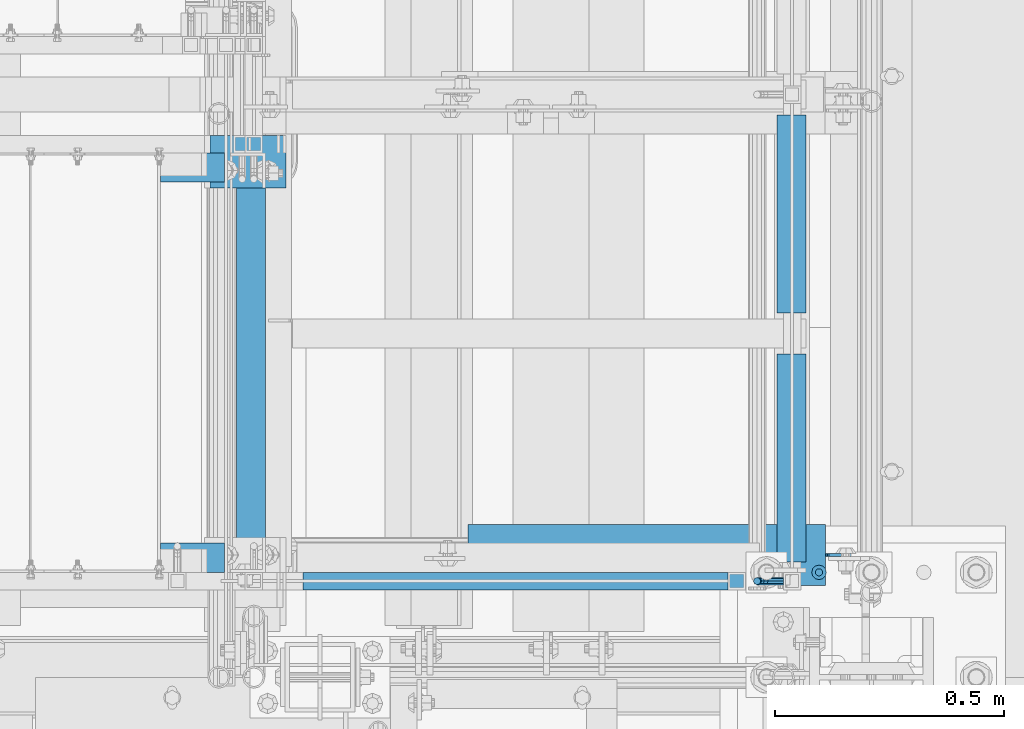
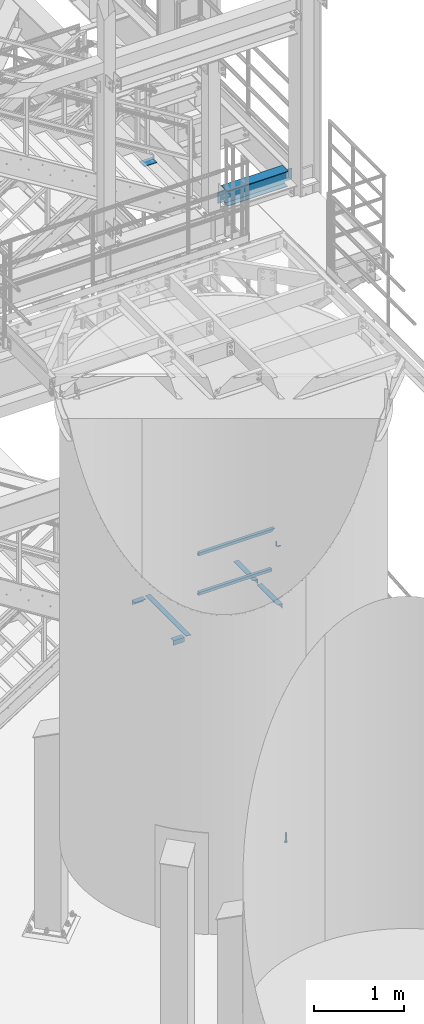
# One storey, part 1156 of 1876: 11 beams, 7 elements without a shape of their own.
"""IFC2X3 building model written with IfcOpenShell, lengths in millimetres."""

import ifcopenshell
import ifcopenshell.guid

model = None  # the IFC model being written
_history = None  # IfcOwnerHistory: only IFC2X3 demands one
_inside = {}  # id of a spatial element -> (the spatial element, [elements in it])
_under = {}  # id of a project, library or spatial element -> (it, [spatial elements below it])
_declared = {}  # id of a project -> (the project, [libraries it declares])
_typed = {}  # id of a type object -> (the type object, [elements of that type])
_made_of = {}  # id of a material, layer set ... -> (it, [elements and type objects made of it])


def new_model(schema):
    """Start an empty IFC model of exactly this schema.

    Asked for "IFC4X3", IfcOpenShell would pick the latest addendum, in which some entities
    have other attributes; the version numbers below select the first issue.
    IFC2X3 requires an IfcOwnerHistory on every rooted entity: one is made here for all.
    """
    global model, _history
    if schema == "IFC4X3":
        model = ifcopenshell.file(schema_version=(4, 3, 0, 0))
    else:
        model = ifcopenshell.file(schema=schema)
    _inside.clear()
    _under.clear()
    _declared.clear()
    _typed.clear()
    _made_of.clear()
    _history = None
    if model.schema == "IFC2X3":
        org = make("IfcOrganization", Name="unknown")
        user = make(
            "IfcPersonAndOrganization",
            ThePerson=make("IfcPerson", FamilyName="unknown"),
            TheOrganization=org,
        )
        app = make(
            "IfcApplication",
            ApplicationDeveloper=org,
            Version="unknown",
            ApplicationFullName="unknown",
            ApplicationIdentifier="unknown",
        )
        _history = make(
            "IfcOwnerHistory",
            OwningUser=user,
            OwningApplication=app,
            ChangeAction="ADDED",
            CreationDate=0,
        )
    return model


def make(cls, **values):
    """One entity of the class cls with the attributes given. An attribute that is None is left unset."""
    return model.create_entity(
        cls, **{name: value for name, value in values.items() if value is not None}
    )


def rooted(cls, **values):
    """An entity with a GlobalId (a new one), such as an element, a storey or a relation."""
    return make(cls, GlobalId=ifcopenshell.guid.new(), OwnerHistory=_history, **values)


def si_unit(unit_type, name, prefix=None):
    """IfcSIUnit, for example si_unit("LENGTHUNIT", "METRE", prefix="MILLI")."""
    return make("IfcSIUnit", UnitType=unit_type, Prefix=prefix, Name=name)


def assignment(units):
    """IfcUnitAssignment: the units of a project."""
    return None if units is None else make("IfcUnitAssignment", Units=units)


def point(xyz):
    """IfcCartesianPoint."""
    return None if xyz is None else make("IfcCartesianPoint", Coordinates=xyz)


def direction(xyz):
    """IfcDirection."""
    return None if xyz is None else make("IfcDirection", DirectionRatios=xyz)


def frame(location, z_axis=None, x_axis=None):
    """IfcAxis2Placement3D, a coordinate frame: its origin and axes. An axis left out is left unset."""
    return make(
        "IfcAxis2Placement3D",
        Location=point(location),
        Axis=direction(z_axis),
        RefDirection=direction(x_axis),
    )


def origin_with_axes():
    """The frame at (0, 0, 0) with the z axis (0, 0, 1) and the x axis (1, 0, 0) written out."""
    return frame((0.0, 0.0, 0.0), z_axis=(0.0, 0.0, 1.0), x_axis=(1.0, 0.0, 0.0))


def place(relative_to, where):
    """IfcLocalPlacement: puts the frame where relative to a parent placement (None: the world)."""
    return make(
        "IfcLocalPlacement", PlacementRelTo=relative_to, RelativePlacement=where
    )


def context(
    kind, dimensions, precision=None, world=None, true_north=None, identifier=None
):
    """IfcGeometricRepresentationContext, for example the 3D "Model" context."""
    return make(
        "IfcGeometricRepresentationContext",
        ContextIdentifier=identifier,
        ContextType=kind,
        CoordinateSpaceDimension=dimensions,
        Precision=precision,
        WorldCoordinateSystem=world,
        TrueNorth=true_north,
    )


def subcontext(parent, identifier, kind, view, scale=None):
    """IfcGeometricRepresentationSubContext, for example "Body" below "Model"."""
    return make(
        "IfcGeometricRepresentationSubContext",
        ContextIdentifier=identifier,
        ContextType=kind,
        ParentContext=parent,
        TargetScale=scale,
        TargetView=view,
    )


def project(units=None, contexts=None):
    """IfcProject with its units and contexts."""
    return rooted(
        "IfcProject",
        Name="project",
        RepresentationContexts=contexts,
        UnitsInContext=assignment(units),
    )


def spatial(cls, under=None, at=None, **own):
    """A site, building, storey or space (cls), placed at a placement, below another one or the project."""
    s = rooted(cls, ObjectPlacement=at, **own)
    if under is not None:
        _under.setdefault(under.id(), (under, []))[1].append(s)
    return s


def faces_of(points, faces, orient=None, outer=None):
    """IfcFace entities. A face is a list of loops; a loop is a list of indices into points, from 0.

    orient and outer hold one flag for each loop. By default every Orientation is true, the
    first loop of a face is its IfcFaceOuterBound and the others are IfcFaceBound.
    """
    made = []
    for i, loops in enumerate(faces):
        bounds = []
        for j, loop in enumerate(loops):
            is_outer = j == 0 if outer is None else outer[i][j]
            bounds.append(
                make(
                    "IfcFaceOuterBound" if is_outer else "IfcFaceBound",
                    Bound=make("IfcPolyLoop", Polygon=[points[k] for k in loop]),
                    Orientation=True if orient is None else orient[i][j],
                )
            )
        made.append(make("IfcFace", Bounds=bounds))
    return made


def faceted_brep(points, faces, orient=None, outer=None, voids=None):
    """IfcFacetedBrep: a solid bounded by flat faces; with voids (closed shells), ...WithVoids."""
    shared = [point(p) for p in points]
    hull = make("IfcClosedShell", CfsFaces=faces_of(shared, faces, orient, outer))
    if voids is None:
        return make("IfcFacetedBrep", Outer=hull)
    return make(
        "IfcFacetedBrepWithVoids",
        Outer=hull,
        Voids=[
            make(cls, CfsFaces=faces_of(shared, fs, o, b)) for cls, fs, o, b in voids
        ],
    )


def shape(context_of_items, identifier, shape_type, items):
    """IfcShapeRepresentation: the items that make up one representation, for example the "Body"."""
    return make(
        "IfcShapeRepresentation",
        ContextOfItems=context_of_items,
        RepresentationIdentifier=identifier,
        RepresentationType=shape_type,
        Items=items,
    )


def material(Name=None, Category=None):
    """IfcMaterial."""
    return make("IfcMaterial", Name=Name, Category=Category)


def made_of(thing, what):
    """Note that an element or type object is made of a material, layer set ...; save() writes the relation."""
    if what is not None:
        _made_of.setdefault(what.id(), (what, []))[1].append(thing)
    return thing


def type_object(cls, material=None, **own):
    """A type object (cls), such as IfcWallType, which elements share."""
    return made_of(rooted(cls, **own), material)


def element(
    cls,
    number,
    at=None,
    inside=None,
    cuts=None,
    type_object=None,
    material=None,
    context=None,
    identifier="Body",
    shape_type=None,
    held_by="IfcProductDefinitionShape",
    body=None,
    shapes=None,
    **own,
):
    """One element of the class cls, such as IfcWall. Its Tag is "e" and its number.

    at: its placement. inside: the storey or other place that contains it. cuts: it is an
    opening in that element (IfcRelVoidsElement). A single representation is given by context,
    identifier, shape_type and body (its items); several are given by shapes. held_by: the class
    of the entity that holds the representations. save() writes the other relations.
    """
    e = rooted(cls, Tag="e%d" % number, ObjectPlacement=at, **own)
    if body is not None:
        shapes = [shape(context, identifier, shape_type, body)]
    if shapes is not None:
        e.Representation = make(held_by, Representations=shapes)
    if inside is not None:
        _inside.setdefault(inside.id(), (inside, []))[1].append(e)
    if cuts is not None:
        rooted(
            "IfcRelVoidsElement", RelatingBuildingElement=cuts, RelatedOpeningElement=e
        )
    if type_object is not None:
        _typed.setdefault(type_object.id(), (type_object, []))[1].append(e)
    return made_of(e, material)


def aggregate(whole, parts):
    """IfcRelAggregates: a whole, such as a stair, and the parts it consists of."""
    return rooted("IfcRelAggregates", RelatingObject=whole, RelatedObjects=parts)


def save(model, path):
    """Write the relations noted so far, then the file.

    IfcRelAggregates (storeys below a building ...), IfcRelContainedInSpatialStructure (elements
    in a storey), IfcRelDefinesByType, IfcRelAssociatesMaterial and IfcRelDeclares: one each for
    every whole, place, type object, material and project.
    """
    for whole, parts in _under.values():
        aggregate(whole, parts)
    for where, things in _inside.values():
        rooted(
            "IfcRelContainedInSpatialStructure",
            RelatedElements=things,
            RelatingStructure=where,
        )
    for kind, things in _typed.values():
        rooted("IfcRelDefinesByType", RelatedObjects=things, RelatingType=kind)
    for what, things in _made_of.values():
        rooted("IfcRelAssociatesMaterial", RelatedObjects=things, RelatingMaterial=what)
    for by, libraries in _declared.values():
        rooted("IfcRelDeclares", RelatingContext=by, RelatedDefinitions=libraries)
    model.write(path)


model = new_model("IFC2X3")

# Units and contexts
model_context = context("Model", 3, precision=1e-05, world=origin_with_axes())
body_context = subcontext(model_context, "Body", "Model", "MODEL_VIEW")
ifc_project = project(units=[si_unit("LENGTHUNIT", "METRE", prefix="MILLI"), si_unit("AREAUNIT", "SQUARE_METRE"), si_unit("VOLUMEUNIT", "CUBIC_METRE"), si_unit("MASSUNIT", "GRAM", prefix="KILO"), si_unit("TIMEUNIT", "SECOND"), si_unit("PLANEANGLEUNIT", "RADIAN"), si_unit("SOLIDANGLEUNIT", "STERADIAN"), si_unit("THERMODYNAMICTEMPERATUREUNIT", "DEGREE_CELSIUS"), si_unit("LUMINOUSINTENSITYUNIT", "LUMEN")], contexts=[model_context])

# Site, building, storey
site_placement = place(None, origin_with_axes())
site = spatial("IfcSite", under=ifc_project, at=site_placement, CompositionType="ELEMENT")
building_placement = place(site_placement, origin_with_axes())
building = spatial("IfcBuilding", under=site, at=building_placement, Name="Undefined", CompositionType="ELEMENT")
storey_placement = place(building_placement, origin_with_axes())
storey = spatial("IfcBuildingStorey", under=building, at=storey_placement, Name="Undefined", CompositionType="ELEMENT", Elevation=0.0)

# Assembly, beams
assembly_1_placement = place(storey_placement, origin_with_axes())
assembly_1 = element("IfcElementAssembly", 1, at=assembly_1_placement, inside=storey, Name="STRINGER", AssemblyPlace="NOTDEFINED", PredefinedType="RIGID_FRAME")
ifc_material_1 = material(Name="STEEL/A36")
beam_type_1 = type_object("IfcBeamType", Name="L2-1/2X2-1/2X1/4", PredefinedType="NOTDEFINED")
beam_1_placement = place(assembly_1_placement, frame((7445.37500036358, -6861.17450143954, 2266.27941824708), z_axis=(0.0, 0.0, -1.0), x_axis=(0.0, 1.0, 0.0)))
beam_1 = element("IfcBeam", 2, at=beam_1_placement, type_object=beam_type_1, material=ifc_material_1, Name="ANGLE", ObjectType="L2-1/2X2-1/2X1/4", context=body_context, shape_type="Brep", body=[
    faceted_brep([(0.0, 31.75, -31.75), (0.0, 31.75, 31.75), (454.024500380441, 31.7499999997981, 31.75), (454.024500380441, 31.7499999997981, -31.75), (0.0, 25.3999999999996, 31.75), (454.024500380438, 25.3999999997977, 31.75), (0.0, 25.3999999999996, -25.3999999999996), (454.024500380438, 25.3999999997977, -25.4000000000001), (0.0, -31.75, -25.3999999999996), (454.024500380413, -31.7500000002019, -25.4000000000001), (0.0, -31.75, -31.75), (454.024500380413, -31.7500000002019, -31.75)], [[[0, 1, 2, 3]], [[1, 4, 5, 2]], [[4, 6, 7, 5]], [[6, 8, 9, 7]], [[8, 10, 11, 9]], [[10, 0, 3, 11]], [[5, 7, 9, 11, 3, 2]], [[10, 8, 6, 4, 1, 0]]]),
])
beam_2_placement = place(assembly_1_placement, frame((7445.3749994372, -6318.25000170957, 2266.27941824787), z_axis=(0.0, 0.0, -1.0), x_axis=(0.0, 1.0, 0.0)))
beam_2 = element("IfcBeam", 3, at=beam_2_placement, type_object=beam_type_1, material=ifc_material_1, Name="ANGLE", ObjectType="L2-1/2X2-1/2X1/4", context=body_context, shape_type="Brep", body=[
    faceted_brep([(0.0, 31.75, -31.75), (0.0, 31.75, 31.75), (431.800000762049, 31.75, 31.75), (431.800000762049, 31.75, -31.75), (0.0, 25.3999999999996, 31.75), (431.800000762049, 25.3999999999996, 31.75), (0.0, 25.3999999999996, -25.3999999999996), (431.800000762049, 25.3999999999996, -25.4000000000001), (0.0, -31.75, -25.3999999999996), (431.800000762049, -31.75, -25.4000000000001), (0.0, -31.75, -31.75), (431.800000762049, -31.75, -31.75)], [[[0, 1, 2, 3]], [[1, 4, 5, 2]], [[4, 6, 7, 5]], [[6, 8, 9, 7]], [[8, 10, 11, 9]], [[10, 0, 3, 11]], [[5, 7, 9, 11, 3, 2]], [[10, 8, 6, 4, 1, 0]]]),
])
beam_3_placement = place(assembly_1_placement, frame((6267.44999998606, -6870.69999887623, 2266.27941810345), z_axis=(0.0, 0.0, -1.0), x_axis=(0.0, 1.0, 0.0)))
beam_3 = element("IfcBeam", 4, at=beam_3_placement, type_object=beam_type_1, material=ifc_material_1, Name="STRINGER", ObjectType="L2-1/2X2-1/2X1/4", context=body_context, shape_type="Brep", body=[
    faceted_brep([(76.1999938964764, 25.4000000000001, -19.0499992370624), (76.1999938964764, 31.75, -19.0499992370624), (0.0, 31.75, -19.0499992370605), (0.0, 25.4000000000001, -19.0499992370605), (76.1999938964791, 25.4000000000001, 31.7499999999982), (76.1999938964791, 31.75, 31.75), (0.0, 25.3999999999996, -25.3999999999996), (0.0, -31.75, -25.3999999999996), (901.69999774321, -31.75, -25.4000000000001), (901.69999774321, 25.3999999999996, -25.4000000000001), (0.0, -31.75, -31.75), (901.69999774321, -31.75, -31.75), (0.0, 31.75, -31.75), (901.69999774321, 31.75, -31.75), (901.69999774321, 31.75, -19.0499992370569), (901.69999774321, 25.3999999999996, -19.0499992370569), (812.800003058393, 31.75, -19.0499992370569), (812.800003058393, 25.4000000000001, -19.0499992370569), (812.800003058393, 25.4000000000001, 31.75), (812.800003058393, 31.75, 31.75)], [[[0, 1, 2, 3]], [[4, 5, 1, 0]], [[6, 7, 8, 9]], [[7, 10, 11, 8]], [[10, 12, 13, 11]], [[9, 8, 11, 13, 14, 15]], [[15, 14, 16, 17]], [[18, 17, 16, 19]], [[3, 6, 9, 15, 17, 18, 4, 0]], [[12, 10, 7, 6, 3, 2]], [[19, 16, 14, 13, 12, 2, 1, 5]], [[18, 19, 5, 4]]]),
])
aggregate(assembly_1, [beam_1, beam_2, beam_3])

assembly_2_placement = place(storey_placement, origin_with_axes())
assembly_2 = element("IfcElementAssembly", 5, at=assembly_2_placement, inside=storey, Name="STRINGER", AssemblyPlace="NOTDEFINED", PredefinedType="RIGID_FRAME")
beam_4_placement = place(assembly_2_placement, frame((6210.29999998606, -6851.65000114537, 2266.27941810345), z_axis=(0.0, 1.0, 0.0), x_axis=(-1.0, 0.0, 0.0)))
beam_4 = element("IfcBeam", 6, at=beam_4_placement, type_object=beam_type_1, material=ifc_material_1, Name="ANGLE", ObjectType="L2-1/2X2-1/2X1/4", context=body_context, shape_type="Brep", body=[
    faceted_brep([(0.0, 31.75, -31.75), (0.0, 31.75, 31.75), (139.700073242188, 31.75, 31.75), (139.700073242188, 31.75, -31.75), (0.0, 25.3999999999996, 31.75), (139.700073242188, 25.3999999999996, 31.75), (0.0, 25.3999999999996, -25.3999999999996), (139.700073242188, 25.3999999999996, -25.3999999999996), (0.0, -31.75, -25.3999999999996), (139.700073242188, -31.75, -25.3999999999996), (0.0, -31.75, -31.75), (139.700073242188, -31.75, -31.75)], [[[0, 1, 2, 3]], [[1, 4, 5, 2]], [[4, 6, 7, 5]], [[6, 8, 9, 7]], [[8, 10, 11, 9]], [[10, 0, 3, 11]], [[5, 7, 9, 11, 3, 2]], [[10, 8, 6, 4, 1, 0]]]),
])
beam_5_placement = place(assembly_2_placement, frame((6070.59992674387, -6000.75000113302, 2266.27941810345), z_axis=(0.0, -1.0, 0.0), x_axis=(1.0, 0.0, 0.0)))
beam_5 = element("IfcBeam", 7, at=beam_5_placement, type_object=beam_type_1, material=ifc_material_1, Name="ANGLE", ObjectType="L2-1/2X2-1/2X1/4", context=body_context, shape_type="Brep", body=[
    faceted_brep([(0.0, 31.75, -31.75), (0.0, 31.75, 31.75), (139.700073242188, 31.75, 31.75), (139.700073242188, 31.75, -31.75), (0.0, 25.3999999999996, 31.75), (139.700073242188, 25.3999999999996, 31.75), (0.0, 25.3999999999996, -25.3999999999996), (139.700073242188, 25.3999999999996, -25.3999999999996), (0.0, -31.75, -25.3999999999996), (139.700073242188, -31.75, -25.3999999999996), (0.0, -31.75, -31.75), (139.700073242188, -31.75, -31.75)], [[[0, 1, 2, 3]], [[1, 4, 5, 2]], [[4, 6, 7, 5]], [[6, 8, 9, 7]], [[8, 10, 11, 9]], [[10, 0, 3, 11]], [[5, 7, 9, 11, 3, 2]], [[10, 8, 6, 4, 1, 0]]]),
])
aggregate(assembly_2, [beam_4, beam_5])

assembly_3_placement = place(storey_placement, origin_with_axes())
assembly_3 = element("IfcElementAssembly", 8, at=assembly_3_placement, inside=storey, Name="RAIL", AssemblyPlace="NOTDEFINED", PredefinedType="RIGID_FRAME")
ifc_material_2 = material()
beam_type_2 = type_object("IfcBeamType", Name="HSS1-1/2X1-1/2X1/8", PredefinedType="NOTDEFINED")
beam_6_placement = place(assembly_3_placement, frame((7345.36250057714, -6902.45000114554, 2847.2086206083), z_axis=(0.0, 0.0, 1.0), x_axis=(-1.0, 0.0, 0.0)))
beam_6 = element("IfcBeam", 9, at=beam_6_placement, type_object=beam_type_2, material=ifc_material_2, Name="RAIL", ObjectType="HSS1-1/2X1-1/2X1/8", context=body_context, shape_type="Brep", body=[
    faceted_brep([(38.0999984689179, 15.8749992829999, -15.8749992829999), (38.0999984689179, -15.8749992829999, -15.8749992829999), (974.57329479457, -15.8749992829999, -15.8749992829999), (974.57329479457, 15.8749992829999, -15.8749992829999), (38.0999984689179, -15.8749992829999, 15.8749992829999), (965.351705125167, -15.8749992829999, 15.8749992829999), (38.0999984689179, 15.8749992829999, 15.8749992829999), (965.351705125167, 15.8749992829999, 15.8749992829999), (38.0999984689179, 19.0499992349996, -19.0499992350001), (38.0999984699993, 19.0499992349996, 19.0499992350001), (964.429546130518, 19.0499992349996, 19.0499992350001), (975.495453789218, 19.0499992349996, -19.0499992350001), (38.0999984699993, -19.0499992349996, 19.0499992350001), (964.429546130518, -19.0499992349996, 19.0499992350001), (38.0999984689179, -19.0499992349996, -19.0499992350001), (975.495453789218, -19.0499992349996, -19.0499992350001)], [[[0, 1, 2, 3]], [[1, 4, 5, 2]], [[4, 6, 7, 5]], [[6, 0, 3, 7]], [[8, 9, 10, 11]], [[9, 12, 13, 10]], [[12, 14, 15, 13]], [[14, 8, 11, 15]], [[13, 15, 11, 10], [5, 7, 3, 2]], [[14, 12, 9, 8], [6, 4, 1, 0]]]),
])
beam_7_placement = place(assembly_3_placement, frame((6375.4000006165, -6902.45000114554, 3380.60862061127), z_axis=(0.0, 0.0, -1.0), x_axis=(1.0, 0.0, 0.0)))
beam_7 = element("IfcBeam", 10, at=beam_7_placement, type_object=beam_type_2, material=ifc_material_2, Name="RAIL", ObjectType="HSS1-1/2X1-1/2X1/8", context=body_context, shape_type="Brep", body=[
    faceted_brep([(4.61079483309095, 15.8749992829999, -15.8749992829999), (4.61079483309095, -15.8749992829999, -15.8749992829999), (966.787500013977, -15.8749992829999, -15.8749992829999), (966.787500013977, 15.8749992829999, -15.8749992829999), (-4.61079482670993, -15.8749992829999, 15.8749992829999), (935.037501447976, -15.8749992829999, 15.8749992829999), (-4.61079482670993, 15.8749992829999, 15.8749992829999), (935.037501447976, 15.8749992829999, 15.8749992829999), (5.5329538267797, 19.0499992349996, -19.0499992350001), (-5.53295382039778, 19.0499992349996, 19.0499992350001), (931.862501495976, 19.0499992349996, 19.0499992350001), (969.962499965976, 19.0499992349996, -19.0499992350001), (-5.53295382039778, -19.0499992349996, 19.0499992350001), (931.862501495976, -19.0499992349996, 19.0499992350001), (5.5329538267797, -19.0499992349996, -19.0499992350001), (969.962499965976, -19.0499992349996, -19.0499992350001)], [[[0, 1, 2, 3]], [[1, 4, 5, 2]], [[4, 6, 7, 5]], [[6, 0, 3, 7]], [[8, 9, 10, 11]], [[9, 12, 13, 10]], [[12, 14, 15, 13]], [[14, 8, 11, 15]], [[13, 15, 11, 10], [5, 7, 3, 2]], [[14, 12, 9, 8], [6, 4, 1, 0]]]),
])
aggregate(assembly_3, [beam_6, beam_7])

# Assembly, beam
assembly_4_placement = place(storey_placement, origin_with_axes())
assembly_4 = element("IfcElementAssembly", 11, at=assembly_4_placement, inside=storey, Name="RAIL", AssemblyPlace="NOTDEFINED", PredefinedType="RIGID_FRAME")
beam_type_3 = type_object("IfcBeamType", PredefinedType="NOTDEFINED")
beam_8_placement = place(assembly_4_placement, frame((7427.912500765, -6902.45000037631, 3123.43417460616), z_axis=(0.0, 1.0, 0.0), x_axis=(-1.0, 0.0, 0.0)))
beam_8 = element("IfcBeam", 12, at=beam_8_placement, type_object=beam_type_3, material=ifc_material_1, Name="BRACKET", context=body_context, shape_type="Brep", body=[
    faceted_brep([(0.0, -7.9375, 0.0), (0.0, -5.61266007566822, -5.61266007566883), (23.8125, -5.61266007566883, -5.61266007566792), (23.8125, -7.9375, 0.0), (0.0, 0.0, -7.9375), (23.8125, 0.0, -7.9375), (0.0, 5.61266007566822, -5.61266007566883), (23.8125, 5.61266007566883, -5.61266007566792), (0.0, 7.9375, 0.0), (23.8125, 7.9375, 0.0), (0.0, 5.61266007566822, 5.61266007566883), (23.8125, 5.61266007566883, 5.61266007566792), (0.0, 0.0, 7.9375), (23.8125, 0.0, 7.9375), (0.0, -5.61266007566822, 5.61266007566883), (23.8125, -5.61266007566883, 5.61266007566792), (39.6077592547981, -4.79562758825341, 0.0), (38.7180815328556, -2.64775556579843, 5.61266007566792), (36.5702095103998, 2.53766620105671, 7.9375), (34.4223374879448, 7.72308796790821, 5.61266007566792), (33.5326597660023, 9.87095999036319, 0.0), (34.4223374879448, 7.72308796790821, -5.61266007566792), (36.5702095103998, 2.53766620105671, -7.9375), (38.7180815328556, -2.64775556579843, -5.61266007566792), (51.3544233967659, 5.79557812911298, -5.61266007566792), (52.9983334724348, 4.15166805344415, 0.0), (47.3856733967659, 9.76432812911298, -7.9375), (43.4169233967659, 13.733078129113, -5.61266007566792), (41.773013321098, 15.3769882047818, 0.0), (43.4169233967659, 13.733078129113, 5.61266007566792), (47.3856733967659, 9.76432812911298, 7.9375), (51.3544233967659, 5.79557812911298, 5.61266007566792), (59.7977570916764, 18.4319199930251, -5.61266007566792), (61.9456291141314, 17.5422422710835, 0.0), (54.6123353248231, 20.5797920154801, -7.9375), (49.4269135579698, 22.727664037935, -5.61266007566792), (47.2790415355148, 23.6173417598766, 0.0), (49.4269135579698, 22.727664037935, 5.61266007566792), (54.6123353248231, 20.5797920154801, 7.9375), (59.7977570916764, 18.4319199930251, 5.61266007566792), (62.7626616015468, 33.3375015258789, -5.61266007566792), (65.0875015258789, 33.3375015258789, 0.0), (57.1500015258789, 33.3375015258789, -7.9375), (51.5373414502101, 33.3375015258789, -5.61266007566792), (49.2125015258789, 33.3375015258789, 0.0), (51.5373414502101, 33.3375015258789, 5.61266007566792), (57.1500015258789, 33.3375015258789, 7.9375), (62.7626616015468, 33.3375015258789, 5.61266007566792), (62.7626616015468, 76.1999969482422, -5.61266007566792), (65.0875015258789, 76.1999969482422, 0.0), (57.1500015258789, 76.1999969482422, -7.9375), (51.537341450211, 76.1999969482422, -5.61266007566792), (49.2125015258789, 76.1999969482422, 0.0), (51.537341450211, 76.1999969482422, 5.61266007566792), (57.1500015258789, 76.1999969482422, 7.9375), (62.7626616015468, 76.1999969482422, 5.61266007566792)], [[[0, 1, 2, 3]], [[1, 4, 5, 2]], [[4, 6, 7, 5]], [[6, 8, 9, 7]], [[8, 10, 11, 9]], [[10, 12, 13, 11]], [[12, 14, 15, 13]], [[14, 0, 3, 15]], [[14, 12, 10, 8, 6, 4, 1, 0]], [[15, 3, 16, 17]], [[13, 15, 17, 18]], [[11, 13, 18, 19]], [[9, 11, 19, 20]], [[7, 9, 20, 21]], [[5, 7, 21, 22]], [[2, 5, 22, 23]], [[3, 2, 23, 16]], [[23, 24, 25, 16]], [[22, 26, 24, 23]], [[21, 27, 26, 22]], [[20, 28, 27, 21]], [[19, 29, 28, 20]], [[18, 30, 29, 19]], [[17, 31, 30, 18]], [[16, 25, 31, 17]], [[24, 32, 33, 25]], [[26, 34, 32, 24]], [[27, 35, 34, 26]], [[28, 36, 35, 27]], [[29, 37, 36, 28]], [[30, 38, 37, 29]], [[31, 39, 38, 30]], [[25, 33, 39, 31]], [[32, 40, 41, 33]], [[34, 42, 40, 32]], [[35, 43, 42, 34]], [[36, 44, 43, 35]], [[37, 45, 44, 36]], [[38, 46, 45, 37]], [[39, 47, 46, 38]], [[33, 41, 47, 39]], [[41, 40, 48, 49]], [[40, 42, 50, 48]], [[42, 43, 51, 50]], [[43, 44, 52, 51]], [[44, 45, 53, 52]], [[45, 46, 54, 53]], [[46, 47, 55, 54]], [[47, 41, 49, 55]], [[50, 51, 52, 53, 54, 55, 49, 48]]]),
])
aggregate(assembly_4, [beam_8])

assembly_5_placement = place(storey_placement, origin_with_axes())
assembly_5 = element("IfcElementAssembly", 13, at=assembly_5_placement, inside=storey, Name="BEAM", AssemblyPlace="NOTDEFINED", PredefinedType="RIGID_FRAME")
ifc_material_3 = material(Name="STEEL/A992")
beam_type_4 = type_object("IfcBeamType", Name="W8X18", PredefinedType="NOTDEFINED")
beam_9_placement = place(assembly_5_placement, frame((6645.67187500001, -6845.30000113401, 8050.2125), z_axis=(0.0, 0.0, 1.0), x_axis=(1.0, 0.0, 0.0)))
beam_9 = element("IfcBeam", 14, at=beam_9_placement, type_object=beam_type_4, material=ifc_material_3, Name="BEAM", ObjectType="W8X18", context=body_context, shape_type="Brep", body=[
    faceted_brep([(867.965624999992, -3.17500000000018, -95.25), (867.965624999992, -66.6750000000002, -95.25), (867.965624999993, -66.6750000000002, -103.1875), (867.965624999993, 66.6750000000002, -103.1875), (867.965624999992, 66.6750000000002, -95.25), (867.965624999992, 3.17500000000018, -95.25), (867.965624999992, 3.17500000000018, -84.1374998092642), (867.965624999992, -3.17500000000018, -84.1374998092642), (868.932354922579, 3.17500000000018, -79.2774202912187), (868.932354922579, -3.17500000000018, -79.2774202912187), (871.685368823058, 3.17500000000018, -75.1572438230651), (871.685368823058, -3.17500000000018, -75.1572438230651), (875.805545291211, 3.17500000000018, -72.4042299225866), (875.805545291211, -3.17500000000018, -72.4042299225866), (880.665624809257, 3.17500000000018, -71.4374999999991), (880.665624809257, -3.17500000000018, -71.4374999999991), (956.865624999992, -3.17500000000018, -71.4374999999991), (956.865624999992, 3.17500000000018, -71.4374999999991), (95.25, 3.17500000000018, 95.25), (95.25, 66.6750000000002, 95.25), (874.315624999992, 66.6750000000002, 95.25), (874.315624999992, 3.17500000000018, 95.25), (101.599999999992, -3.17500000000018, -84.1374998092642), (101.599999999992, 3.17500000000018, -84.1374998092642), (101.599999999992, 3.17500000000018, -95.25), (101.599999999992, 66.6750000000002, -95.25), (101.599999999992, 66.6750000000002, -103.1875), (101.599999999992, -66.6750000000002, -103.1875), (101.599999999992, -66.6750000000002, -95.25), (101.599999999992, -3.17500000000018, -95.25), (100.633270077405, -3.17500000000018, -79.2774202912187), (100.633270077405, 3.17500000000018, -79.2774202912187), (97.8802561769262, -3.17500000000018, -75.1572438230651), (97.8802561769262, 3.17500000000018, -75.1572438230651), (93.7600797087725, -3.17500000000018, -72.4042299225866), (93.7600797087725, 3.17500000000018, -72.4042299225866), (88.900000190727, -3.17500000000018, -71.4374999999991), (88.900000190727, 3.17500000000018, -71.4374999999991), (12.6999999999925, -3.17500000000018, -71.4374999999991), (12.6999999999925, 3.17500000000018, -71.4374999999991), (12.7000000000007, -3.17500000000018, 77.7874999999985), (12.7000000000007, 3.17500000000018, 77.7874999999985), (82.5500001907349, -3.17500000000018, 77.7874999999949), (82.5500001907349, 3.17500000000018, 77.7874999999949), (87.4100797087804, -3.17500000000018, 78.7542299225825), (87.4100797087804, 3.17500000000018, 78.7542299225825), (91.530256176934, -3.17500000000018, 81.50724382306), (91.530256176934, 3.17500000000018, 81.50724382306), (94.2832700774125, -3.17500000000018, 85.6274202912136), (94.2832700774125, 3.17500000000018, 85.6274202912136), (95.25, -3.17500000000018, 90.48749980926), (95.25, 3.17500000000018, 90.48749980926), (95.25, -66.6750000000002, 103.1875), (95.25, 66.6750000000002, 103.1875), (95.25, -3.17500000000018, 95.25), (95.25, -66.6750000000002, 95.25), (874.315624999992, -3.17500000000018, 95.25), (874.315624999992, -66.6750000000002, 95.25), (874.315624999992, -66.6750000000002, 103.1875), (874.315624999992, 66.6750000000002, 103.1875), (874.315624999992, -3.17500000000018, 90.4874998092664), (874.315624999992, 3.17500000000018, 90.4874998092664), (875.28235492258, -3.17500000000018, 85.6274202912209), (875.28235492258, 3.17500000000018, 85.6274202912209), (878.035368823058, -3.17500000000018, 81.5072438230673), (878.035368823058, 3.17500000000018, 81.5072438230673), (882.155545291212, -3.17500000000018, 78.7542299225888), (882.155545291212, 3.17500000000018, 78.7542299225888), (887.015624809257, -3.17500000000018, 77.7875000000013), (887.015624809257, 3.17500000000018, 77.7875000000013), (956.865624999992, -3.17500000000018, 77.7875000000013), (956.865624999992, 3.17500000000018, 77.7875000000013)], [[[0, 1, 2, 3, 4, 5, 6, 7]], [[7, 6, 8, 9]], [[9, 8, 10, 11]], [[11, 10, 12, 13]], [[13, 12, 14, 15]], [[16, 15, 14, 17]], [[18, 19, 20, 21]], [[22, 23, 24, 25, 26, 27, 28, 29]], [[30, 31, 23, 22]], [[32, 33, 31, 30]], [[34, 35, 33, 32]], [[36, 37, 35, 34]], [[38, 39, 37, 36]], [[40, 41, 39, 38]], [[42, 43, 41, 40]], [[44, 45, 43, 42]], [[46, 47, 45, 44]], [[48, 49, 47, 46]], [[50, 51, 49, 48]], [[52, 53, 19, 18, 51, 50, 54, 55]], [[55, 54, 56, 57]], [[52, 55, 57, 58]], [[53, 52, 58, 59]], [[19, 53, 59, 20]], [[58, 57, 56, 60, 61, 21, 20, 59]], [[62, 63, 61, 60]], [[64, 65, 63, 62]], [[66, 67, 65, 64]], [[68, 69, 67, 66]], [[70, 71, 69, 68]], [[71, 70, 16, 17]], [[12, 10, 8, 6, 5, 24, 23, 31, 33, 35, 37, 39, 41, 43, 45, 47, 49, 51, 18, 21, 61, 63, 65, 67, 69, 71, 17, 14]], [[25, 24, 5, 4]], [[26, 25, 4, 3]], [[27, 26, 3, 2]], [[28, 27, 2, 1]], [[29, 28, 1, 0]], [[70, 68, 66, 64, 62, 60, 56, 54, 50, 48, 46, 44, 42, 40, 38, 36, 34, 32, 30, 22, 29, 0, 7, 9, 11, 13, 15, 16]]]),
])
aggregate(assembly_5, [beam_9])

assembly_6_placement = place(storey_placement, origin_with_axes())
assembly_6 = element("IfcElementAssembly", 15, at=assembly_6_placement, inside=storey, Name="STRINGER", AssemblyPlace="NOTDEFINED", PredefinedType="RIGID_FRAME")
beam_type_5 = type_object("IfcBeamType", PredefinedType="NOTDEFINED")
beam_10_placement = place(assembly_6_placement, frame((6343.65, -5988.05000114537, 8156.57499999916), z_axis=(0.0, -1.0, 0.0), x_axis=(-1.0, 0.0, 0.0)))
beam_10 = element("IfcBeam", 16, at=beam_10_placement, type_object=beam_type_5, material=ifc_material_1, Name="PLATE", context=body_context, shape_type="Brep", body=[
    faceted_brep([(0.0, 3.17499999999927, -57.1499999999996), (0.0, 3.17499999999927, 57.1499999999996), (165.099999999999, 3.17499999999927, 57.1499999999996), (165.099999999999, 3.17499999999927, -57.1499999999996), (0.0, -3.17499999999927, 57.1499999999996), (165.099999999999, -3.17499999999927, 57.1499999999996), (0.0, -3.17499999999927, -57.1499999999996), (165.099999999999, -3.17499999999927, -57.1499999999996)], [[[0, 1, 2, 3]], [[1, 4, 5, 2]], [[4, 6, 7, 5]], [[6, 0, 3, 7]], [[5, 7, 3, 2]], [[6, 4, 1, 0]]]),
])
aggregate(assembly_6, [beam_10])

assembly_7_placement = place(storey_placement, origin_with_axes())
assembly_7 = element("IfcElementAssembly", 17, at=assembly_7_placement, inside=storey, Name="TEMPLATE", AssemblyPlace="NOTDEFINED", PredefinedType="RIGID_FRAME")
ifc_material_4 = material(Name="STEEL/A108")
beam_type_6 = type_object("IfcBeamType", Name="5/8-DIA_HEADED ANCHOR STUD", PredefinedType="NOTDEFINED")
beam_11_placement = place(assembly_7_placement, frame((7505.7, -6883.4, -793.75), z_axis=(1.0, 0.0, 0.0), x_axis=(0.0, 0.0, -1.0)))
beam_11 = element("IfcBeam", 18, at=beam_11_placement, type_object=beam_type_6, material=ifc_material_4, Name="HEADED ANCHOR STUD", ObjectType="5/8-DIA_HEADED ANCHOR STUD", context=body_context, shape_type="Brep", body=[
    faceted_brep([(0.0, -7.94000005722046, 0.0), (0.0, -6.86999988555908, -3.97000002861023), (116.84, -6.86999988555908, -3.97000002861023), (116.84, -7.94000005722046, 0.0), (0.0, -3.97000002861023, -6.86999988555908), (116.84, -3.97000002861023, -6.86999988555908), (0.0, 0.0, -7.94000005722046), (116.84, 0.0, -7.94000005722046), (0.0, 3.97000002861023, -6.86999988555908), (116.84, 3.97000002861023, -6.86999988555908), (0.0, 6.86999988555908, -3.97000002861023), (116.84, 6.86999988555908, -3.97000002861023), (0.0, 7.94000005722046, 0.0), (116.84, 7.94000005722046, 0.0), (0.0, 6.86999988555908, 3.97000002861023), (116.84, 6.86999988555908, 3.97000002861023), (0.0, 3.97000002861023, 6.86999988555908), (116.84, 3.97000002861023, 6.86999988555908), (0.0, 0.0, 7.94000005722046), (116.84, 0.0, 7.94000005722046), (0.0, -3.97000002861023, 6.86999988555908), (116.84, -3.97000002861023, 6.86999988555908), (0.0, -6.86999988555908, 3.97000002861023), (116.84, -6.86999988555908, 3.97000002861023), (118.11, -13.75, -7.94000005722046), (118.11, -15.8800001144409, 0.0), (118.11, -7.94000005722046, -13.75), (118.11, 0.0, -15.8800001144409), (118.11, 7.94000005722046, -13.75), (118.11, 13.75, -7.94000005722046), (118.11, 15.8800001144409, 0.0), (118.11, 13.75, 7.94000005722046), (118.11, 7.94000005722046, 13.75), (118.11, 0.0, 15.8800001144409), (118.11, -7.94000005722046, 13.75), (118.11, -13.75, 7.94000005722046), (127.0, -13.75, -7.94000005722046), (127.0, -15.8800001144409, 0.0), (127.0, -7.94000005722046, -13.75), (127.0, 0.0, -15.8800001144409), (127.0, 7.94000005722046, -13.75), (127.0, 13.75, -7.94000005722046), (127.0, 15.8800001144409, 0.0), (127.0, 13.75, 7.94000005722046), (127.0, 7.94000005722046, 13.75), (127.0, 0.0, 15.8800001144409), (127.0, -7.94000005722046, 13.75), (127.0, -13.75, 7.94000005722046)], [[[0, 1, 2, 3]], [[1, 4, 5, 2]], [[4, 6, 7, 5]], [[6, 8, 9, 7]], [[8, 10, 11, 9]], [[10, 12, 13, 11]], [[12, 14, 15, 13]], [[14, 16, 17, 15]], [[16, 18, 19, 17]], [[18, 20, 21, 19]], [[20, 22, 23, 21]], [[22, 0, 3, 23]], [[22, 20, 18, 16, 14, 12, 10, 8, 6, 4, 1, 0]], [[3, 2, 24, 25]], [[2, 5, 26, 24]], [[5, 7, 27, 26]], [[7, 9, 28, 27]], [[9, 11, 29, 28]], [[11, 13, 30, 29]], [[13, 15, 31, 30]], [[15, 17, 32, 31]], [[17, 19, 33, 32]], [[19, 21, 34, 33]], [[21, 23, 35, 34]], [[23, 3, 25, 35]], [[25, 24, 36, 37]], [[24, 26, 38, 36]], [[26, 27, 39, 38]], [[27, 28, 40, 39]], [[28, 29, 41, 40]], [[29, 30, 42, 41]], [[30, 31, 43, 42]], [[31, 32, 44, 43]], [[32, 33, 45, 44]], [[33, 34, 46, 45]], [[34, 35, 47, 46]], [[35, 25, 37, 47]], [[38, 39, 40, 41, 42, 43, 44, 45, 46, 47, 37, 36]]]),
])
aggregate(assembly_7, [beam_11])

save(model, "model.ifc")
